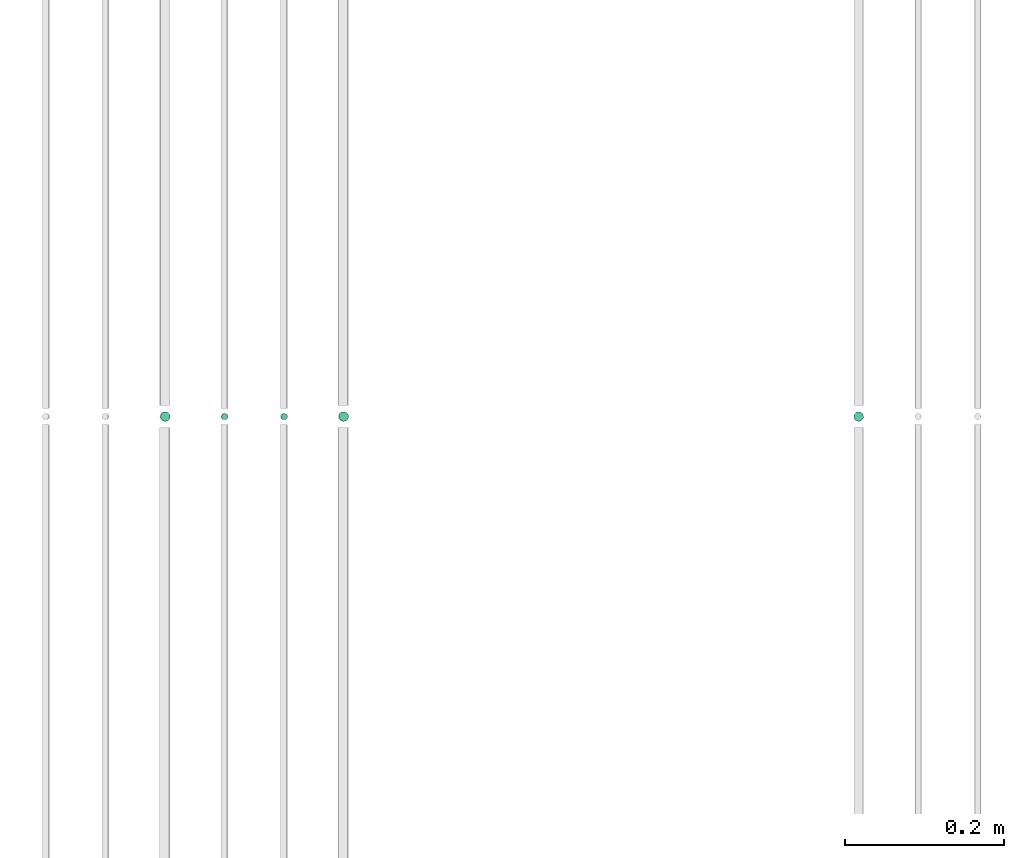
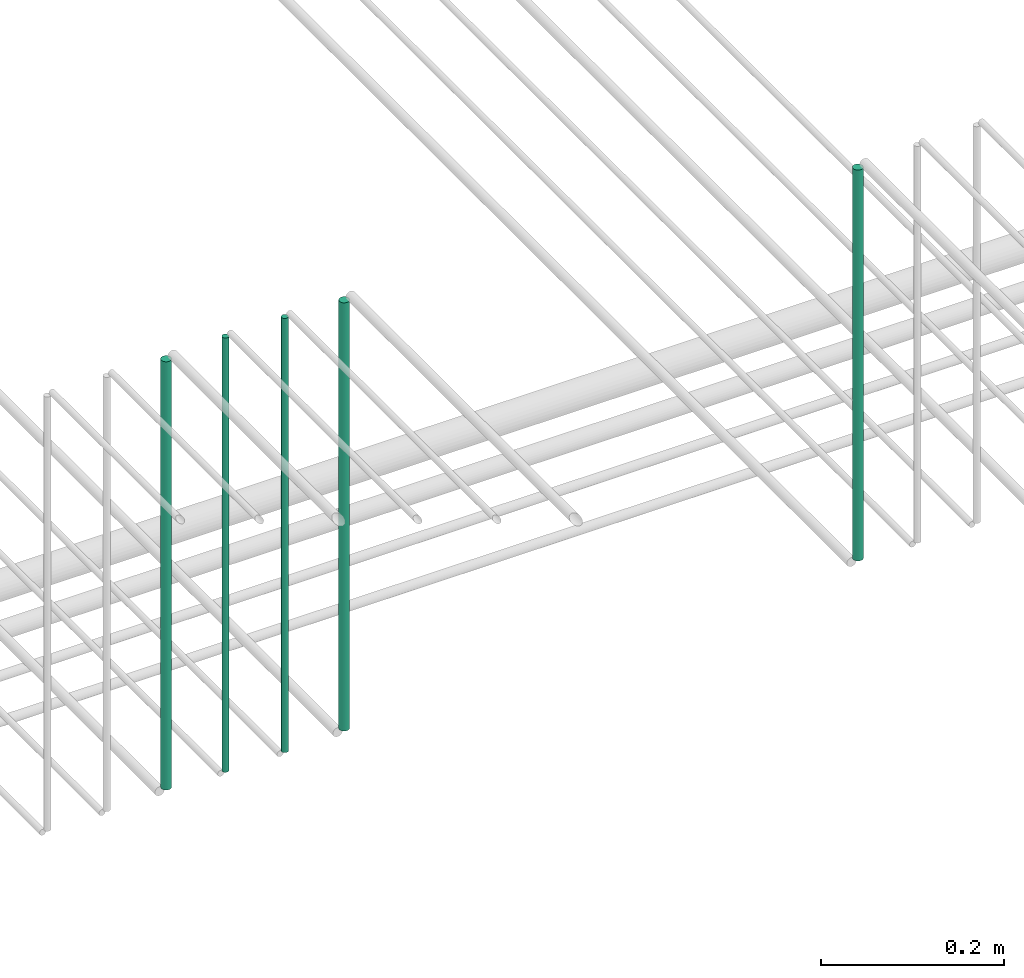
# One storey, part 175 of 331: 5 flow segments.
"""IFC2X3 building model written with IfcOpenShell, lengths in millimetres."""

from ifc_helpers import new_model, entity, si_unit, converted_unit, derived_unit, direction, frame, frame_2d, origin, origin_2d_with_axis, place, context, subcontext, project, spatial, circle, extrude, type_object, element, save


model = new_model("IFC2X3")

# Units and contexts
model_context = context("Model", 3, precision=0.01, world=origin(), true_north=direction((6.12303176911189e-17, 1.0)))
body_context = subcontext(model_context, "Body", "Model", "MODEL_VIEW")
ifc_project = project(units=[si_unit("LENGTHUNIT", "METRE", prefix="MILLI"), si_unit("AREAUNIT", "SQUARE_METRE"), si_unit("VOLUMEUNIT", "CUBIC_METRE"), converted_unit("PLANEANGLEUNIT", "DEGREE", entity("IfcRatioMeasure", 0.0174532925199433), si_unit("PLANEANGLEUNIT", "RADIAN"), dimensions=[0, 0, 0, 0, 0, 0, 0]), si_unit("MASSUNIT", "GRAM", prefix="KILO"), derived_unit("MASSDENSITYUNIT", [(si_unit("MASSUNIT", "GRAM", prefix="KILO"), 1), (si_unit("LENGTHUNIT", "METRE"), -3)]), derived_unit("MOMENTOFINERTIAUNIT", [(si_unit("LENGTHUNIT", "METRE"), 4)]), si_unit("TIMEUNIT", "SECOND"), si_unit("FREQUENCYUNIT", "HERTZ"), si_unit("THERMODYNAMICTEMPERATUREUNIT", "DEGREE_CELSIUS"), derived_unit("THERMALTRANSMITTANCEUNIT", [(si_unit("MASSUNIT", "GRAM", prefix="KILO"), 1), (si_unit("THERMODYNAMICTEMPERATUREUNIT", "KELVIN"), -1), (si_unit("TIMEUNIT", "SECOND"), -3)]), derived_unit("VOLUMETRICFLOWRATEUNIT", [(si_unit("LENGTHUNIT", "METRE"), 3), (si_unit("TIMEUNIT", "SECOND"), -1)]), derived_unit("MASSFLOWRATEUNIT", [(si_unit("MASSUNIT", "GRAM", prefix="KILO"), 1), (si_unit("TIMEUNIT", "SECOND"), -1)]), derived_unit("ROTATIONALFREQUENCYUNIT", [(si_unit("TIMEUNIT", "SECOND"), -1)]), si_unit("ELECTRICCURRENTUNIT", "AMPERE"), si_unit("ELECTRICVOLTAGEUNIT", "VOLT"), si_unit("POWERUNIT", "WATT"), si_unit("FORCEUNIT", "NEWTON", prefix="KILO"), si_unit("ILLUMINANCEUNIT", "LUX"), si_unit("LUMINOUSFLUXUNIT", "LUMEN"), si_unit("LUMINOUSINTENSITYUNIT", "CANDELA"), derived_unit("USERDEFINED", [(si_unit("MASSUNIT", "GRAM", prefix="KILO"), -1), (si_unit("LENGTHUNIT", "METRE"), -2), (si_unit("TIMEUNIT", "SECOND"), 3), (si_unit("LUMINOUSFLUXUNIT", "LUMEN"), 1)]), derived_unit("LINEARVELOCITYUNIT", [(si_unit("LENGTHUNIT", "METRE"), 1), (si_unit("TIMEUNIT", "SECOND"), -1)]), si_unit("PRESSUREUNIT", "PASCAL"), derived_unit("USERDEFINED", [(si_unit("LENGTHUNIT", "METRE"), -2), (si_unit("MASSUNIT", "GRAM", prefix="KILO"), 1), (si_unit("TIMEUNIT", "SECOND"), -2)]), derived_unit("LINEARFORCEUNIT", [(si_unit("MASSUNIT", "GRAM", prefix="KILO"), 1), (si_unit("LENGTHUNIT", "METRE"), 1), (si_unit("TIMEUNIT", "SECOND"), -2), (si_unit("LENGTHUNIT", "METRE"), -1)]), derived_unit("PLANARFORCEUNIT", [(si_unit("MASSUNIT", "GRAM", prefix="KILO"), 1), (si_unit("LENGTHUNIT", "METRE"), 1), (si_unit("TIMEUNIT", "SECOND"), -2), (si_unit("LENGTHUNIT", "METRE"), -2)])], contexts=[model_context])

# Site, building, storey
site_placement = place(None, frame((0.0, -0.00077364408347762, 0.0)))
site = spatial("IfcSite", under=ifc_project, at=site_placement, CompositionType="ELEMENT")
building_placement = place(site_placement, origin())
building = spatial("IfcBuilding", under=site, at=building_placement, CompositionType="ELEMENT")
storey_placement = place(building_placement, origin())
storey = spatial("IfcBuildingStorey", under=building, at=storey_placement, CompositionType="ELEMENT", Elevation=0.0)

# Flow segments
pipe_segment_type = type_object("IfcPipeSegmentType", PredefinedType="NOTDEFINED")
flow_segment_1_placement = place(storey_placement, frame((44487.6371022588, 5636.02529159143, 14564.0)))
element("IfcFlowSegment", 1, at=flow_segment_1_placement, inside=storey, type_object=pipe_segment_type, context=body_context, shape_type="SweptSolid", body=[
    extrude(circle(Radius=6.0, at=origin_2d_with_axis()), frame((7.59527223591454, 7.59527223591562, 0.0), z_axis=(0.0, 0.0, 1.0), x_axis=(-1.0, 0.0, 0.0)), (0.0, 0.0, 1.0), 521.999997792771),
])
flow_segment_2_placement = place(storey_placement, frame((43613.5132590561, 5636.02529159143, 14564.0)))
element("IfcFlowSegment", 2, at=flow_segment_2_placement, inside=storey, type_object=pipe_segment_type, context=body_context, shape_type="SweptSolid", body=[
    extrude(circle(Radius=6.0, at=origin_2d_with_axis()), frame((7.59527223591454, 7.59527223591562, 0.0), z_axis=(0.0, 0.0, 1.0), x_axis=(-1.0, 0.0, 0.0)), (0.0, 0.0, 1.0), 572.0),
])
flow_segment_3_placement = place(storey_placement, frame((43690.5132590561, 5638.02529159143, 14560.0)))
element("IfcFlowSegment", 3, at=flow_segment_3_placement, inside=storey, type_object=pipe_segment_type, context=body_context, shape_type="SweptSolid", body=[
    extrude(circle(Radius=4.0, at=origin_2d_with_axis()), frame((5.59527223591499, 5.59527223591607, 0.0), z_axis=(0.0, 0.0, 1.0), x_axis=(-1.0, 0.0, 0.0)), (0.0, 0.0, 1.0), 580.000000000018),
])
flow_segment_4_placement = place(storey_placement, frame((43765.5132590561, 5638.02529159144, 14560.0)))
element("IfcFlowSegment", 4, at=flow_segment_4_placement, inside=storey, type_object=pipe_segment_type, context=body_context, shape_type="SweptSolid", body=[
    extrude(circle(Radius=4.0, at=frame_2d((0.0, -1.08286712929839e-12), x_axis=(1.0, 0.0))), frame((5.59527223591499, 5.59527223591499, 0.0), z_axis=(0.0, 0.0, 1.0), x_axis=(-1.0, 0.0, 0.0)), (0.0, 0.0, 1.0), 579.999996143001),
])
flow_segment_5_placement = place(storey_placement, frame((43838.5132590627, 5636.02529159143, 14564.0)))
element("IfcFlowSegment", 5, at=flow_segment_5_placement, inside=storey, type_object=pipe_segment_type, context=body_context, shape_type="SweptSolid", body=[
    extrude(circle(Radius=6.0, at=origin_2d_with_axis()), frame((7.59527223591454, 7.59527223591562, 0.0), z_axis=(0.0, 0.0, 1.0), x_axis=(-1.0, 0.0, 0.0)), (0.0, 0.0, 1.0), 571.999997792779),
])

save(model, "model.ifc")
